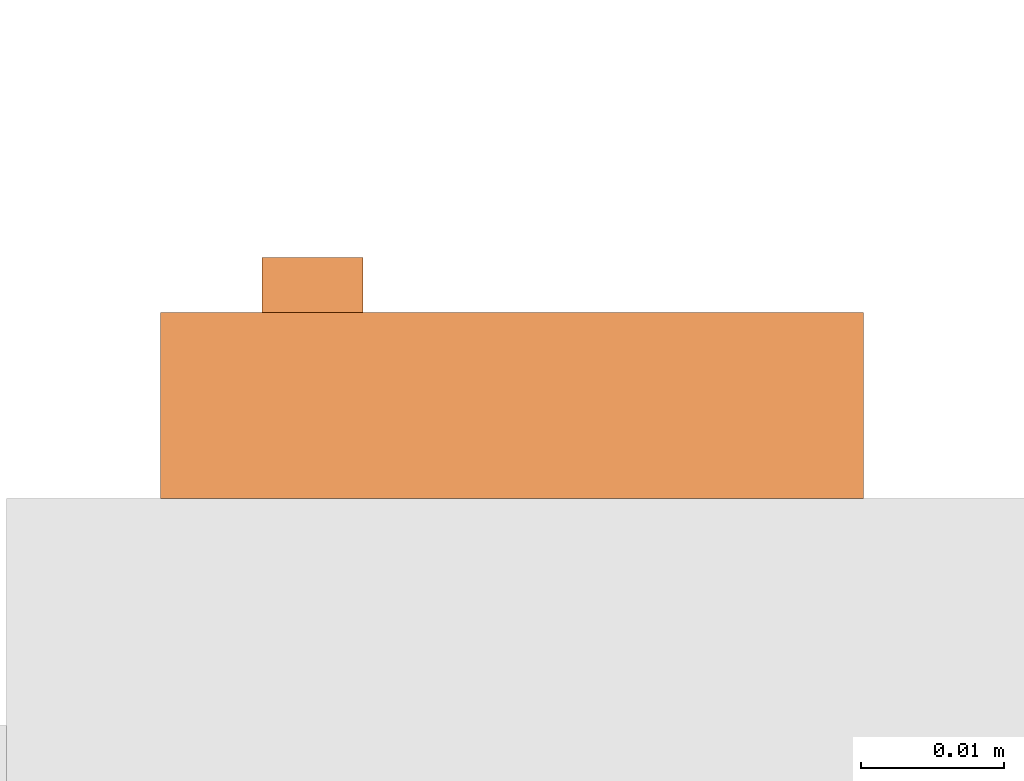
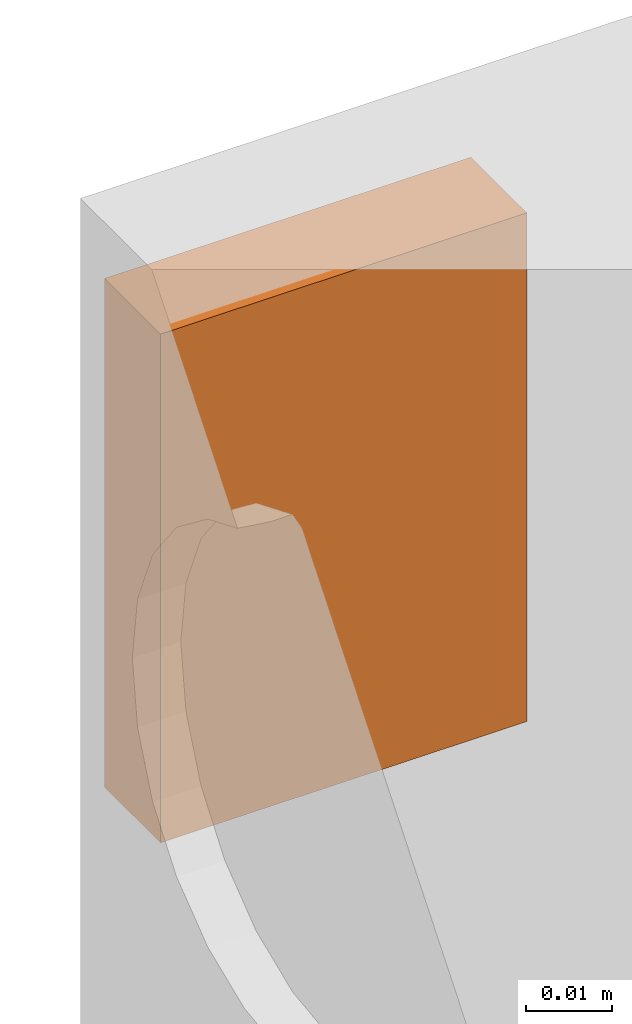
# One storey, part 4 of 4: 1 proxy.
"""IFC2X3 building model written with IfcOpenShell, lengths in millimetres."""

from ifc_helpers import new_model, entity, si_unit, converted_unit, derived_unit, direction, frame, origin, place, context, subcontext, project, spatial, faceted_brep, source, transform, mapped, material, material_list, type_object, type_shapes, element, save


model = new_model("IFC2X3")

# Units and contexts
model_context = context("Model", 3, precision=0.01, world=origin(), true_north=direction((6.12303176911189e-17, 1.0)))
body_context = subcontext(model_context, "Body", "Model", "MODEL_VIEW")
ifc_project = project(units=[si_unit("LENGTHUNIT", "METRE", prefix="MILLI"), si_unit("AREAUNIT", "SQUARE_METRE"), si_unit("VOLUMEUNIT", "CUBIC_METRE"), converted_unit("PLANEANGLEUNIT", "DEGREE", entity("IfcRatioMeasure", 0.0174532925199433), si_unit("PLANEANGLEUNIT", "RADIAN"), dimensions=[0, 0, 0, 0, 0, 0, 0]), si_unit("MASSUNIT", "GRAM", prefix="KILO"), derived_unit("MASSDENSITYUNIT", [(si_unit("MASSUNIT", "GRAM", prefix="KILO"), 1), (si_unit("LENGTHUNIT", "METRE"), -3)]), derived_unit("MOMENTOFINERTIAUNIT", [(si_unit("LENGTHUNIT", "METRE"), 4)]), si_unit("TIMEUNIT", "SECOND"), si_unit("FREQUENCYUNIT", "HERTZ"), si_unit("THERMODYNAMICTEMPERATUREUNIT", "DEGREE_CELSIUS"), derived_unit("THERMALTRANSMITTANCEUNIT", [(si_unit("MASSUNIT", "GRAM", prefix="KILO"), 1), (si_unit("THERMODYNAMICTEMPERATUREUNIT", "KELVIN"), -1), (si_unit("TIMEUNIT", "SECOND"), -3)]), derived_unit("VOLUMETRICFLOWRATEUNIT", [(si_unit("LENGTHUNIT", "METRE"), 3), (si_unit("TIMEUNIT", "SECOND"), -1)]), derived_unit("MASSFLOWRATEUNIT", [(si_unit("MASSUNIT", "GRAM", prefix="KILO"), 1), (si_unit("TIMEUNIT", "SECOND"), -1)]), derived_unit("ROTATIONALFREQUENCYUNIT", [(si_unit("TIMEUNIT", "SECOND"), -1)]), si_unit("ELECTRICCURRENTUNIT", "AMPERE"), si_unit("ELECTRICVOLTAGEUNIT", "VOLT"), si_unit("POWERUNIT", "WATT"), si_unit("FORCEUNIT", "NEWTON", prefix="KILO"), si_unit("ILLUMINANCEUNIT", "LUX"), si_unit("LUMINOUSFLUXUNIT", "LUMEN"), si_unit("LUMINOUSINTENSITYUNIT", "CANDELA"), derived_unit("USERDEFINED", [(si_unit("MASSUNIT", "GRAM", prefix="KILO"), -1), (si_unit("LENGTHUNIT", "METRE"), -2), (si_unit("TIMEUNIT", "SECOND"), 3), (si_unit("LUMINOUSFLUXUNIT", "LUMEN"), 1)]), derived_unit("LINEARVELOCITYUNIT", [(si_unit("LENGTHUNIT", "METRE"), 1), (si_unit("TIMEUNIT", "SECOND"), -1)]), si_unit("PRESSUREUNIT", "PASCAL"), derived_unit("USERDEFINED", [(si_unit("LENGTHUNIT", "METRE"), -2), (si_unit("MASSUNIT", "GRAM", prefix="KILO"), 1), (si_unit("TIMEUNIT", "SECOND"), -2)]), derived_unit("LINEARFORCEUNIT", [(si_unit("MASSUNIT", "GRAM", prefix="KILO"), 1), (si_unit("LENGTHUNIT", "METRE"), 1), (si_unit("TIMEUNIT", "SECOND"), -2), (si_unit("LENGTHUNIT", "METRE"), -1)]), derived_unit("PLANARFORCEUNIT", [(si_unit("MASSUNIT", "GRAM", prefix="KILO"), 1), (si_unit("LENGTHUNIT", "METRE"), 1), (si_unit("TIMEUNIT", "SECOND"), -2), (si_unit("LENGTHUNIT", "METRE"), -2)])], contexts=[model_context])

# Site, building, storey
site_placement = place(None, frame((0.0, 2493.83037508239, 0.0)))
site = spatial("IfcSite", under=ifc_project, at=site_placement, CompositionType="ELEMENT")
building_placement = place(site_placement, origin())
building = spatial("IfcBuilding", under=site, at=building_placement, CompositionType="ELEMENT")
storey_placement = place(building_placement, frame((0.0, 0.0, 24000.0)))
storey = spatial("IfcBuildingStorey", under=building, at=storey_placement, CompositionType="ELEMENT", Elevation=24000.0)

# Proxy
ifc_material_1 = material()
ifc_material_2 = material()
ifc_material_list = material_list([ifc_material_1, ifc_material_2])
building_element_proxy_type = type_object("IfcBuildingElementProxyType", PredefinedType="NOTDEFINED", material=ifc_material_1)
shared_shape = source(origin(), body_context, "Body", "Brep", [
    faceted_brep([(0.0, 9.70151456467493, 9.73834612738113), (0.0, 8.853718255961, 10.0895148565803), (0.0, 8.12569906110286, 10.6481436325617), (0.0, 7.5670702851215, 11.3761628274197), (0.0, 7.21590155592234, 12.2239591361336), (0.0, 7.09612444206653, 13.1337566413141), (0.0, 7.21590155592233, 14.0435541464947), (0.0, 7.56707028512149, 14.8913504552086), (0.0, 8.12569906110284, 15.6193696500666), (0.0, 8.85371825596098, 16.177998426048), (0.0, 9.7015145646749, 16.5291671552471), (0.0, 10.6113120698554, 16.648944269103), (0.0, 11.5211095750359, 16.5291671552471), (0.0, 12.3689058837499, 16.177998426048), (0.0, 13.096925078608, 15.6193696500666), (0.0, 13.6555538545894, 14.8913504552086), (0.0, 14.0067225837885, 14.0435541464947), (0.0, 14.1264996976443, 13.1337566413141), (0.0, 14.0067225837885, 12.2239591361336), (0.0, 13.6555538545894, 11.3761628274197), (0.0, 13.096925078608, 10.6481436325617), (0.0, 12.3689058837499, 10.0895148565803), (0.0, 11.521109575036, 9.73834612738113), (0.0, 10.6113120698554, 9.61856901352529), (3.82281759831273, 9.7015145646749, 16.5291671552471), (3.82281759831273, 8.85371825596097, 16.177998426048), (3.82281759831273, 8.12569906110284, 15.6193696500666), (3.82281759831273, 7.56707028512148, 14.8913504552086), (3.82281759831273, 7.21590155592232, 14.0435541464947), (3.82281759831273, 7.09612444206653, 13.1337566413141), (3.82281759831273, 7.21590155592233, 12.2239591361336), (3.82281759831273, 7.56707028512149, 11.3761628274197), (3.82281759831273, 8.12569906110285, 10.6481436325617), (3.82281759831273, 8.85371825596099, 10.0895148565803), (3.82281759831273, 9.70151456467492, 9.73834612738113), (3.82281759831273, 10.6113120698554, 9.61856901352529), (3.82281759831274, 11.5211095750359, 9.73834612738113), (3.82281759831274, 12.3689058837499, 10.0895148565803), (3.82281759831274, 13.096925078608, 10.6481436325617), (3.82281759831274, 13.6555538545894, 11.3761628274197), (3.82281759831274, 14.0067225837885, 12.2239591361336), (3.82281759831274, 14.1264996976443, 13.1337566413141), (3.82281759831274, 14.0067225837885, 14.0435541464947), (3.82281759831274, 13.6555538545894, 14.8913504552086), (3.82281759831274, 13.096925078608, 15.6193696500666), (3.82281759831274, 12.3689058837499, 16.177998426048), (3.82281759831274, 11.5211095750359, 16.5291671552471), (3.82281759831273, 10.6113120698554, 16.648944269103)], [[[0, 1, 2, 3, 4, 5, 6, 7, 8, 9, 10, 11, 12, 13, 14, 15, 16, 17, 18, 19, 20, 21, 22, 23]], [[24, 25, 26, 27, 28, 29, 30, 31, 32, 33, 34, 35, 36, 37, 38, 39, 40, 41, 42, 43, 44, 45, 46, 47]], [[18, 17, 41, 40]], [[39, 19, 18, 40]], [[21, 20, 38, 37]], [[39, 38, 20, 19]], [[37, 36, 22, 21]], [[23, 22, 36, 35]], [[34, 0, 23, 35]], [[33, 1, 0, 34]], [[3, 2, 32, 31]], [[2, 1, 33, 32]], [[31, 30, 4, 3]], [[5, 4, 30, 29]], [[28, 6, 5, 29]], [[27, 7, 6, 28]], [[9, 8, 26, 25]], [[27, 26, 8, 7]], [[10, 9, 25, 24]], [[11, 10, 24, 47]], [[46, 12, 11, 47]], [[45, 13, 12, 46]], [[15, 14, 44, 43]], [[45, 44, 14, 13]], [[16, 15, 43, 42]], [[17, 16, 42, 41]]]),
    faceted_brep([(16.8239233594376, 49.056494355586, 72.0190470640746), (3.82281759831279, 49.056494355586, 72.0190470640746), (3.82281759831271, 0.0, 72.0190470640746), (16.8239233594376, 0.0, 72.0190470640746), (16.8239233594376, 0.0, 0.0), (3.82281759831271, 0.0, 0.0), (3.82281759831279, 49.056494355586, 0.0), (16.8239233594376, 49.056494355586, 0.0), (3.82281759831277, 38.0970267269559, 16.0375565533757), (3.82281759831278, 41.0008266390171, 13.1337566413144), (3.82281759831277, 38.0970267269559, 10.2299567292531), (3.82281759831277, 35.1932268148946, 13.1337566413144), (8.82281759831278, 41.0008266390171, 13.1337566413144), (8.82281759831278, 38.0970267269559, 10.2299567292531), (8.82281759831277, 35.1932268148946, 13.1337566413144), (8.82281759831278, 38.0970267269559, 16.0375565533757)], [[[0, 1, 2, 3]], [[4, 5, 6, 7]], [[1, 8, 2]], [[8, 1, 9]], [[6, 9, 1]], [[9, 6, 10]], [[5, 10, 6]], [[2, 11, 5]], [[5, 11, 10]], [[11, 2, 8]], [[3, 2, 5, 4]], [[0, 3, 4, 7]], [[1, 0, 7, 6]], [[12, 13, 14, 15]], [[10, 13, 12, 9]], [[11, 14, 13, 10]], [[8, 15, 14, 11]], [[9, 12, 15, 8]]]),
])
type_shapes(building_element_proxy_type, [shared_shape])
proxy_placement = place(storey_placement, frame((71006.749450684, 12215.1709478924, 2700.0), z_axis=(0.0, 0.0, 1.0), x_axis=(0.0, -1.0, 0.0)))
element("IfcBuildingElementProxy", 1, at=proxy_placement, inside=storey, type_object=building_element_proxy_type, material=ifc_material_list, context=body_context, shape_type="MappedRepresentation", body=[
    mapped(shared_shape, transform((0.0, 0.0, 0.0), scale=1.0)),
])

save(model, "model.ifc")
